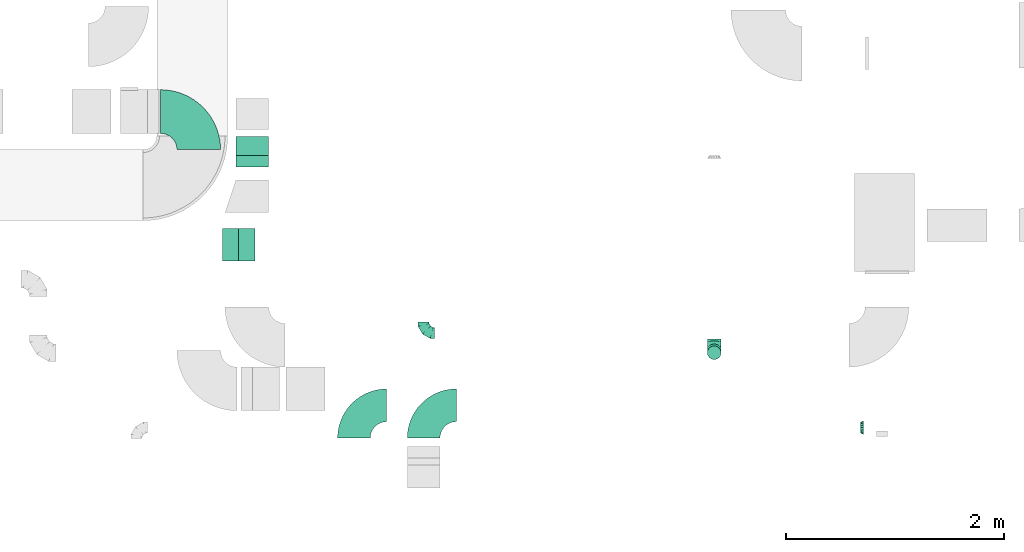
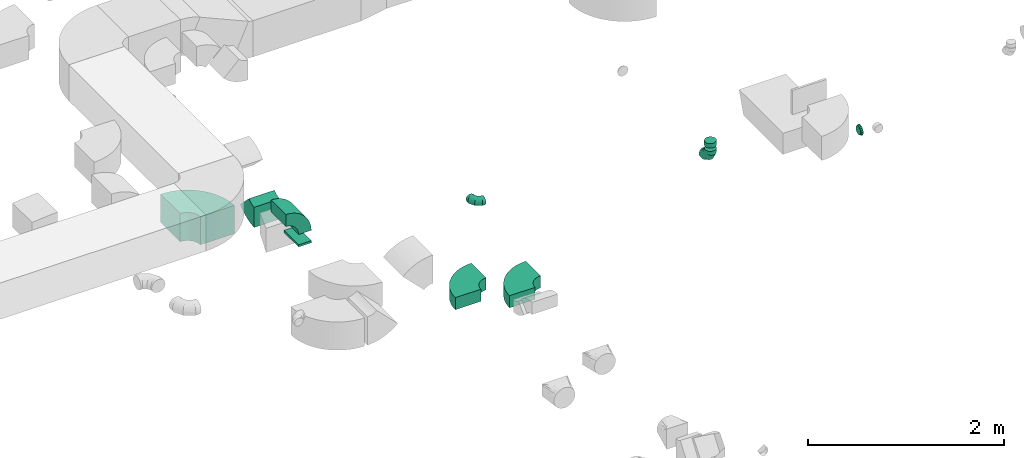
# One storey, part 11 of 44: 10 flow fittings.
"""IFC2X3 building model written with IfcOpenShell, lengths in millimetres."""

import ifcopenshell
import ifcopenshell.guid

model = None  # the IFC model being written
_history = None  # IfcOwnerHistory: only IFC2X3 demands one
_inside = {}  # id of a spatial element -> (the spatial element, [elements in it])
_under = {}  # id of a project, library or spatial element -> (it, [spatial elements below it])
_declared = {}  # id of a project -> (the project, [libraries it declares])
_typed = {}  # id of a type object -> (the type object, [elements of that type])
_made_of = {}  # id of a material, layer set ... -> (it, [elements and type objects made of it])


def new_model(schema):
    """Start an empty IFC model of exactly this schema.

    Asked for "IFC4X3", IfcOpenShell would pick the latest addendum, in which some entities
    have other attributes; the version numbers below select the first issue.
    IFC2X3 requires an IfcOwnerHistory on every rooted entity: one is made here for all.
    """
    global model, _history
    if schema == "IFC4X3":
        model = ifcopenshell.file(schema_version=(4, 3, 0, 0))
    else:
        model = ifcopenshell.file(schema=schema)
    _inside.clear()
    _under.clear()
    _declared.clear()
    _typed.clear()
    _made_of.clear()
    _history = None
    if model.schema == "IFC2X3":
        org = make("IfcOrganization", Name="unknown")
        user = make(
            "IfcPersonAndOrganization",
            ThePerson=make("IfcPerson", FamilyName="unknown"),
            TheOrganization=org,
        )
        app = make(
            "IfcApplication",
            ApplicationDeveloper=org,
            Version="unknown",
            ApplicationFullName="unknown",
            ApplicationIdentifier="unknown",
        )
        _history = make(
            "IfcOwnerHistory",
            OwningUser=user,
            OwningApplication=app,
            ChangeAction="ADDED",
            CreationDate=0,
        )
    return model


def make(cls, **values):
    """One entity of the class cls with the attributes given. An attribute that is None is left unset."""
    return model.create_entity(
        cls, **{name: value for name, value in values.items() if value is not None}
    )


def entity(cls, *values):
    """Any entity or typed value of the class cls, its attributes in the order of the schema. None: left unset."""
    e = model.create_entity(cls)
    for i, value in enumerate(values):
        if value is not None:
            e[i] = value
    return e


def rooted(cls, **values):
    """An entity with a GlobalId (a new one), such as an element, a storey or a relation."""
    return make(cls, GlobalId=ifcopenshell.guid.new(), OwnerHistory=_history, **values)


def si_unit(unit_type, name, prefix=None):
    """IfcSIUnit, for example si_unit("LENGTHUNIT", "METRE", prefix="MILLI")."""
    return make("IfcSIUnit", UnitType=unit_type, Prefix=prefix, Name=name)


def converted_unit(unit_type, name, factor, base, dimensions=None, offset=None):
    """IfcConversionBasedUnit, such as the inch: factor (a typed value) times the base unit."""
    return make(
        "IfcConversionBasedUnit"
        if offset is None
        else "IfcConversionBasedUnitWithOffset",
        ConversionOffset=offset,
        Dimensions=None
        if dimensions is None
        else entity("IfcDimensionalExponents", *dimensions),
        UnitType=unit_type,
        Name=name,
        ConversionFactor=make(
            "IfcMeasureWithUnit", ValueComponent=factor, UnitComponent=base
        ),
    )


def derived_unit(unit_type, elements):
    """IfcDerivedUnit: a product of units, each with its exponent."""
    return make(
        "IfcDerivedUnit",
        Elements=[
            make("IfcDerivedUnitElement", Unit=unit, Exponent=power)
            for unit, power in elements
        ],
        UnitType=unit_type,
    )


def assignment(units):
    """IfcUnitAssignment: the units of a project."""
    return None if units is None else make("IfcUnitAssignment", Units=units)


def point(xyz):
    """IfcCartesianPoint."""
    return None if xyz is None else make("IfcCartesianPoint", Coordinates=xyz)


def direction(xyz):
    """IfcDirection."""
    return None if xyz is None else make("IfcDirection", DirectionRatios=xyz)


def frame(location, z_axis=None, x_axis=None):
    """IfcAxis2Placement3D, a coordinate frame: its origin and axes. An axis left out is left unset."""
    return make(
        "IfcAxis2Placement3D",
        Location=point(location),
        Axis=direction(z_axis),
        RefDirection=direction(x_axis),
    )


def frame_2d(location, x_axis=None):
    """IfcAxis2Placement2D, a coordinate frame in the plane: its origin and x axis."""
    return make(
        "IfcAxis2Placement2D", Location=point(location), RefDirection=direction(x_axis)
    )


def origin():
    """The frame at (0, 0, 0) with its axes left unset."""
    return frame((0.0, 0.0, 0.0))


def origin_2d_with_axis():
    """The frame at (0, 0) in the plane with the x axis (1, 0) written out."""
    return frame_2d((0.0, 0.0), x_axis=(1.0, 0.0))


def place(relative_to, where):
    """IfcLocalPlacement: puts the frame where relative to a parent placement (None: the world)."""
    return make(
        "IfcLocalPlacement", PlacementRelTo=relative_to, RelativePlacement=where
    )


def context(
    kind, dimensions, precision=None, world=None, true_north=None, identifier=None
):
    """IfcGeometricRepresentationContext, for example the 3D "Model" context."""
    return make(
        "IfcGeometricRepresentationContext",
        ContextIdentifier=identifier,
        ContextType=kind,
        CoordinateSpaceDimension=dimensions,
        Precision=precision,
        WorldCoordinateSystem=world,
        TrueNorth=true_north,
    )


def subcontext(parent, identifier, kind, view, scale=None):
    """IfcGeometricRepresentationSubContext, for example "Body" below "Model"."""
    return make(
        "IfcGeometricRepresentationSubContext",
        ContextIdentifier=identifier,
        ContextType=kind,
        ParentContext=parent,
        TargetScale=scale,
        TargetView=view,
    )


def project(units=None, contexts=None):
    """IfcProject with its units and contexts."""
    return rooted(
        "IfcProject",
        Name="project",
        RepresentationContexts=contexts,
        UnitsInContext=assignment(units),
    )


def spatial(cls, under=None, at=None, **own):
    """A site, building, storey or space (cls), placed at a placement, below another one or the project."""
    s = rooted(cls, ObjectPlacement=at, **own)
    if under is not None:
        _under.setdefault(under.id(), (under, []))[1].append(s)
    return s


def polyline(points):
    """IfcPolyline through the points."""
    return make("IfcPolyline", Points=[point(p) for p in points])


def circle_curve(where, radius):
    """IfcCircle in the frame where."""
    return make("IfcCircle", Position=where, Radius=radius)


def parameter(value):
    """IfcParameterValue: where a trimmed curve begins or ends, as a parameter of its basis curve."""
    return model.create_entity("IfcParameterValue", value)


def trimmed(basis, trim1, trim2, sense, master):
    """IfcTrimmedCurve: the piece of a basis curve between two trims."""
    return make(
        "IfcTrimmedCurve",
        BasisCurve=basis,
        Trim1=trim1,
        Trim2=trim2,
        SenseAgreement=sense,
        MasterRepresentation=master,
    )


def segment(curve, same_sense, transition):
    """IfcCompositeCurveSegment."""
    return make(
        "IfcCompositeCurveSegment",
        Transition=transition,
        SameSense=same_sense,
        ParentCurve=curve,
    )


def composite_curve(segments, self_intersect=None):
    """IfcCompositeCurve: segments joined end to end."""
    return make("IfcCompositeCurve", Segments=segments, SelfIntersect=self_intersect)


def profile(cls, at=None, kind="AREA", **sizes):
    """A parametric profile (cls). Its sizes go by their IFC names, for example OverallWidth=200.0."""
    return make(cls, ProfileType=kind, Position=at, **sizes)


def rectangle(**sizes):
    """IfcRectangleProfileDef."""
    return profile("IfcRectangleProfileDef", **sizes)


def outline(outer, holes=None, kind="AREA"):
    """IfcArbitraryClosedProfileDef: a profile drawn as a closed curve; with holes, ...WithVoids."""
    if holes is None:
        return make("IfcArbitraryClosedProfileDef", ProfileType=kind, OuterCurve=outer)
    return make(
        "IfcArbitraryProfileDefWithVoids",
        ProfileType=kind,
        OuterCurve=outer,
        InnerCurves=holes,
    )


def extrude(swept, where, along, depth):
    """IfcExtrudedAreaSolid: the profile swept, set in the frame where, extruded along a direction by depth."""
    return make(
        "IfcExtrudedAreaSolid",
        SweptArea=swept,
        Position=where,
        ExtrudedDirection=direction(along),
        Depth=depth,
    )


def faces_of(points, faces, orient=None, outer=None):
    """IfcFace entities. A face is a list of loops; a loop is a list of indices into points, from 0.

    orient and outer hold one flag for each loop. By default every Orientation is true, the
    first loop of a face is its IfcFaceOuterBound and the others are IfcFaceBound.
    """
    made = []
    for i, loops in enumerate(faces):
        bounds = []
        for j, loop in enumerate(loops):
            is_outer = j == 0 if outer is None else outer[i][j]
            bounds.append(
                make(
                    "IfcFaceOuterBound" if is_outer else "IfcFaceBound",
                    Bound=make("IfcPolyLoop", Polygon=[points[k] for k in loop]),
                    Orientation=True if orient is None else orient[i][j],
                )
            )
        made.append(make("IfcFace", Bounds=bounds))
    return made


def faceted_brep(points, faces, orient=None, outer=None, voids=None):
    """IfcFacetedBrep: a solid bounded by flat faces; with voids (closed shells), ...WithVoids."""
    shared = [point(p) for p in points]
    hull = make("IfcClosedShell", CfsFaces=faces_of(shared, faces, orient, outer))
    if voids is None:
        return make("IfcFacetedBrep", Outer=hull)
    return make(
        "IfcFacetedBrepWithVoids",
        Outer=hull,
        Voids=[
            make(cls, CfsFaces=faces_of(shared, fs, o, b)) for cls, fs, o, b in voids
        ],
    )


def shape(context_of_items, identifier, shape_type, items):
    """IfcShapeRepresentation: the items that make up one representation, for example the "Body"."""
    return make(
        "IfcShapeRepresentation",
        ContextOfItems=context_of_items,
        RepresentationIdentifier=identifier,
        RepresentationType=shape_type,
        Items=items,
    )


def source(mapping_origin, context_of_items, identifier, shape_type, items):
    """IfcRepresentationMap: a shape defined once, which mapped items show again and again."""
    return make(
        "IfcRepresentationMap",
        MappingOrigin=mapping_origin,
        MappedRepresentation=shape(context_of_items, identifier, shape_type, items),
    )


def transform(
    local_origin,
    x_axis=None,
    y_axis=None,
    z_axis=None,
    scale=None,
    scale2=None,
    scale3=None,
    uniform=True,
):
    """IfcCartesianTransformationOperator3D, or its non-uniform kind. x_axis, y_axis, z_axis: its Axis1, 2, 3."""
    if uniform:
        return make(
            "IfcCartesianTransformationOperator3D",
            Axis1=direction(x_axis),
            Axis2=direction(y_axis),
            LocalOrigin=point(local_origin),
            Scale=scale,
            Axis3=direction(z_axis),
        )
    return make(
        "IfcCartesianTransformationOperator3DnonUniform",
        Axis1=direction(x_axis),
        Axis2=direction(y_axis),
        LocalOrigin=point(local_origin),
        Scale=scale,
        Axis3=direction(z_axis),
        Scale2=scale2,
        Scale3=scale3,
    )


def mapped(mapping_source, mapping_target):
    """IfcMappedItem: shows the shape of a source again, moved by a transform."""
    return make(
        "IfcMappedItem", MappingSource=mapping_source, MappingTarget=mapping_target
    )


def material(Name=None, Category=None):
    """IfcMaterial."""
    return make("IfcMaterial", Name=Name, Category=Category)


def made_of(thing, what):
    """Note that an element or type object is made of a material, layer set ...; save() writes the relation."""
    if what is not None:
        _made_of.setdefault(what.id(), (what, []))[1].append(thing)
    return thing


def type_object(cls, material=None, **own):
    """A type object (cls), such as IfcWallType, which elements share."""
    return made_of(rooted(cls, **own), material)


def type_shapes(of_type, sources):
    """Give a type object the sources (RepresentationMaps) that its elements show as mapped items."""
    of_type.RepresentationMaps = sources


def element(
    cls,
    number,
    at=None,
    inside=None,
    cuts=None,
    type_object=None,
    material=None,
    context=None,
    identifier="Body",
    shape_type=None,
    held_by="IfcProductDefinitionShape",
    body=None,
    shapes=None,
    **own,
):
    """One element of the class cls, such as IfcWall. Its Tag is "e" and its number.

    at: its placement. inside: the storey or other place that contains it. cuts: it is an
    opening in that element (IfcRelVoidsElement). A single representation is given by context,
    identifier, shape_type and body (its items); several are given by shapes. held_by: the class
    of the entity that holds the representations. save() writes the other relations.
    """
    e = rooted(cls, Tag="e%d" % number, ObjectPlacement=at, **own)
    if body is not None:
        shapes = [shape(context, identifier, shape_type, body)]
    if shapes is not None:
        e.Representation = make(held_by, Representations=shapes)
    if inside is not None:
        _inside.setdefault(inside.id(), (inside, []))[1].append(e)
    if cuts is not None:
        rooted(
            "IfcRelVoidsElement", RelatingBuildingElement=cuts, RelatedOpeningElement=e
        )
    if type_object is not None:
        _typed.setdefault(type_object.id(), (type_object, []))[1].append(e)
    return made_of(e, material)


def aggregate(whole, parts):
    """IfcRelAggregates: a whole, such as a stair, and the parts it consists of."""
    return rooted("IfcRelAggregates", RelatingObject=whole, RelatedObjects=parts)


def save(model, path):
    """Write the relations noted so far, then the file.

    IfcRelAggregates (storeys below a building ...), IfcRelContainedInSpatialStructure (elements
    in a storey), IfcRelDefinesByType, IfcRelAssociatesMaterial and IfcRelDeclares: one each for
    every whole, place, type object, material and project.
    """
    for whole, parts in _under.values():
        aggregate(whole, parts)
    for where, things in _inside.values():
        rooted(
            "IfcRelContainedInSpatialStructure",
            RelatedElements=things,
            RelatingStructure=where,
        )
    for kind, things in _typed.values():
        rooted("IfcRelDefinesByType", RelatedObjects=things, RelatingType=kind)
    for what, things in _made_of.values():
        rooted("IfcRelAssociatesMaterial", RelatedObjects=things, RelatingMaterial=what)
    for by, libraries in _declared.values():
        rooted("IfcRelDeclares", RelatingContext=by, RelatedDefinitions=libraries)
    model.write(path)


model = new_model("IFC2X3")

# Units and contexts
model_context = context("Model", 3, precision=0.01, world=origin(), true_north=direction((6.12303176911189e-17, 1.0)))
body_context = subcontext(model_context, "Body", "Model", "MODEL_VIEW")
ifc_project = project(units=[si_unit("LENGTHUNIT", "METRE", prefix="MILLI"), si_unit("AREAUNIT", "SQUARE_METRE"), si_unit("VOLUMEUNIT", "CUBIC_METRE"), converted_unit("PLANEANGLEUNIT", "DEGREE", entity("IfcRatioMeasure", 0.0174532925199433), si_unit("PLANEANGLEUNIT", "RADIAN"), dimensions=[0, 0, 0, 0, 0, 0, 0]), si_unit("MASSUNIT", "GRAM", prefix="KILO"), derived_unit("MASSDENSITYUNIT", [(si_unit("MASSUNIT", "GRAM", prefix="KILO"), 1), (si_unit("LENGTHUNIT", "METRE"), -3)]), derived_unit("MOMENTOFINERTIAUNIT", [(si_unit("LENGTHUNIT", "METRE"), 4)]), si_unit("TIMEUNIT", "SECOND"), si_unit("FREQUENCYUNIT", "HERTZ"), si_unit("THERMODYNAMICTEMPERATUREUNIT", "DEGREE_CELSIUS"), derived_unit("THERMALTRANSMITTANCEUNIT", [(si_unit("MASSUNIT", "GRAM", prefix="KILO"), 1), (si_unit("THERMODYNAMICTEMPERATUREUNIT", "KELVIN"), -1), (si_unit("TIMEUNIT", "SECOND"), -3)]), derived_unit("VOLUMETRICFLOWRATEUNIT", [(si_unit("LENGTHUNIT", "METRE"), 3), (si_unit("TIMEUNIT", "SECOND"), -1)]), derived_unit("MASSFLOWRATEUNIT", [(si_unit("MASSUNIT", "GRAM", prefix="KILO"), 1), (si_unit("TIMEUNIT", "SECOND"), -1)]), derived_unit("ROTATIONALFREQUENCYUNIT", [(si_unit("TIMEUNIT", "SECOND"), -1)]), si_unit("ELECTRICCURRENTUNIT", "AMPERE"), si_unit("ELECTRICVOLTAGEUNIT", "VOLT"), si_unit("POWERUNIT", "WATT"), si_unit("FORCEUNIT", "NEWTON", prefix="KILO"), si_unit("ILLUMINANCEUNIT", "LUX"), si_unit("LUMINOUSFLUXUNIT", "LUMEN"), si_unit("LUMINOUSINTENSITYUNIT", "CANDELA"), derived_unit("USERDEFINED", [(si_unit("MASSUNIT", "GRAM", prefix="KILO"), -1), (si_unit("LENGTHUNIT", "METRE"), -2), (si_unit("TIMEUNIT", "SECOND"), 3), (si_unit("LUMINOUSFLUXUNIT", "LUMEN"), 1)]), derived_unit("LINEARVELOCITYUNIT", [(si_unit("LENGTHUNIT", "METRE"), 1), (si_unit("TIMEUNIT", "SECOND"), -1)]), si_unit("PRESSUREUNIT", "PASCAL"), derived_unit("USERDEFINED", [(si_unit("LENGTHUNIT", "METRE"), -2), (si_unit("MASSUNIT", "GRAM", prefix="KILO"), 1), (si_unit("TIMEUNIT", "SECOND"), -2)]), derived_unit("LINEARFORCEUNIT", [(si_unit("MASSUNIT", "GRAM", prefix="KILO"), 1), (si_unit("LENGTHUNIT", "METRE"), 1), (si_unit("TIMEUNIT", "SECOND"), -2), (si_unit("LENGTHUNIT", "METRE"), -1)]), derived_unit("PLANARFORCEUNIT", [(si_unit("MASSUNIT", "GRAM", prefix="KILO"), 1), (si_unit("LENGTHUNIT", "METRE"), 1), (si_unit("TIMEUNIT", "SECOND"), -2), (si_unit("LENGTHUNIT", "METRE"), -2)])], contexts=[model_context])

# Site, building, storey
site_placement = place(None, origin())
site = spatial("IfcSite", under=ifc_project, at=site_placement, CompositionType="ELEMENT")
building_placement = place(site_placement, origin())
building = spatial("IfcBuilding", under=site, at=building_placement, CompositionType="ELEMENT")
storey_placement = place(building_placement, frame((0.0, 0.0, 15900.0)))
storey = spatial("IfcBuildingStorey", under=building, at=storey_placement, CompositionType="ELEMENT", Elevation=15900.0)

# Flow fittings
ifc_material = material()
duct_fitting_type_1 = type_object("IfcDuctFittingType", PredefinedType="NOTDEFINED", material=ifc_material)
shared_shape_1 = source(origin(), body_context, "Body", "SweptSolid", [
    extrude(rectangle(XDim=26.0960000000005, YDim=300.0, at=origin_2d_with_axis()), frame((6.95, 0.0, -75.0)), (0.0, 0.0, 1.0), 150.0),
])
type_shapes(duct_fitting_type_1, [shared_shape_1])
flow_fitting_1_placement = place(storey_placement, frame((18500.31, 11046.76, 3000.0), z_axis=(1.0, 0.0, 0.0), x_axis=(0.0, 0.0, 1.0)))
element("IfcFlowFitting", 1, at=flow_fitting_1_placement, inside=storey, type_object=duct_fitting_type_1, material=ifc_material, context=body_context, shape_type="MappedRepresentation", body=[
    mapped(shared_shape_1, transform((0.0, 0.0, 0.0), scale=1.0)),
])
duct_fitting_type_2 = type_object("IfcDuctFittingType", PredefinedType="NOTDEFINED", material=ifc_material)
shared_shape_2 = source(origin(), body_context, "Body", "Brep", [
    faceted_brep([(-100.0, 0.0, -50.0), (-100.0, -12.94, -48.3), (-100.0, -25.0, -43.3), (-100.0, -35.36, -35.36), (-100.0, -43.3, -25.0), (-100.0, -48.3, -12.94), (-100.0, -50.0, 0.0), (-100.0, -48.3, 12.94), (-100.0, -43.3, 25.0), (-100.0, -35.36, 35.36), (-100.0, -25.0, 43.3), (-100.0, -12.94, 48.3), (-100.0, 0.0, 50.0), (-100.0, 12.94, 48.3), (-100.0, 25.0, 43.3), (-100.0, 35.36, 35.36), (-100.0, 43.3, 25.0), (-100.0, 48.3, 12.94), (-100.0, 50.0, 0.0), (-100.0, 48.3, -12.94), (-100.0, 43.3, -25.0), (-100.0, 35.36, -35.36), (-100.0, 25.0, -43.3), (-100.0, 12.94, -48.3), (-76.67, 12.94, 48.3), (-79.9, 25.0, 43.3), (-73.21, 0.0, 50.0), (-82.68, 35.36, 35.36), (-86.15, 48.3, 12.94), (-86.6, 50.0, 0.0), (-84.81, 43.3, 25.0), (-84.81, 43.3, -25.0), (-82.68, 35.36, -35.36), (-86.15, 48.3, -12.94), (-76.67, 12.94, -48.3), (-73.21, 0.0, -50.0), (-79.9, 25.0, -43.3), (-69.74, -12.94, -48.3), (-66.51, -25.0, -43.3), (-63.73, -35.36, -35.36), (-61.6, -43.3, -25.0), (-60.26, -48.3, -12.94), (-59.81, -50.0, 0.0), (-60.26, -48.3, 12.94), (-61.6, -43.3, 25.0), (-63.73, -35.36, 35.36), (-66.51, -25.0, 43.3), (-69.74, -12.94, 48.3), (-36.27, 36.27, 48.3), (-45.1, 45.1, 43.3), (-26.79, 26.79, 50.0), (-52.68, 52.68, 35.36), (-58.49, 58.49, 25.0), (-62.15, 62.15, 12.94), (-63.4, 63.4, 0.0), (-62.15, 62.15, -12.94), (-58.49, 58.49, -25.0), (-52.68, 52.68, -35.36), (-36.27, 36.27, -48.3), (-26.79, 26.79, -50.0), (-45.1, 45.1, -43.3), (-17.32, 17.32, -48.3), (-8.49, 8.49, -43.3), (-0.91, 0.91, -35.36), (4.9, -4.9, -25.0), (8.56, -8.56, -12.94), (9.81, -9.81, 0.0), (8.56, -8.56, 12.94), (4.9, -4.9, 25.0), (-0.91, 0.91, 35.36), (-8.49, 8.49, 43.3), (-17.32, 17.32, 48.3), (-12.94, 76.67, 48.3), (-25.0, 79.9, 43.3), (0.0, 73.21, 50.0), (-35.36, 82.68, 35.36), (-43.3, 84.81, 25.0), (-48.3, 86.15, 12.94), (-50.0, 86.6, 0.0), (-48.3, 86.15, -12.94), (-43.3, 84.81, -25.0), (-35.36, 82.68, -35.36), (-12.94, 76.67, -48.3), (0.0, 73.21, -50.0), (-25.0, 79.9, -43.3), (12.94, 69.74, -48.3), (25.0, 66.51, -43.3), (35.36, 63.73, -35.36), (43.3, 61.6, -25.0), (48.3, 60.26, -12.94), (50.0, 59.81, 0.0), (48.3, 60.26, 12.94), (43.3, 61.6, 25.0), (35.36, 63.73, 35.36), (25.0, 66.51, 43.3), (12.94, 69.74, 48.3), (-12.94, 100.0, -48.3), (-25.0, 100.0, -43.3), (-35.36, 100.0, -35.36), (-43.3, 100.0, -25.0), (-48.3, 100.0, -12.94), (-50.0, 100.0, 0.0), (-48.3, 100.0, 12.94), (-43.3, 100.0, 25.0), (-35.36, 100.0, 35.36), (-25.0, 100.0, 43.3), (-12.94, 100.0, 48.3), (0.0, 100.0, 50.0), (12.94, 100.0, 48.3), (25.0, 100.0, 43.3), (35.36, 100.0, 35.36), (43.3, 100.0, 25.0), (48.3, 100.0, 12.94), (50.0, 100.0, 0.0), (48.3, 100.0, -12.94), (43.3, 100.0, -25.0), (35.36, 100.0, -35.36), (25.0, 100.0, -43.3), (12.94, 100.0, -48.3), (0.0, 100.0, -50.0)], [[[0, 1, 2, 3, 4, 5, 6, 7, 8, 9, 10, 11, 12, 13, 14, 15, 16, 17, 18, 19, 20, 21, 22, 23]], [[24, 25, 14, 13]], [[26, 24, 13, 12]], [[14, 25, 27, 15]], [[28, 29, 18, 17]], [[30, 28, 17, 16]], [[15, 27, 30, 16]], [[20, 31, 32, 21]], [[33, 31, 20, 19]], [[18, 29, 33, 19]], [[34, 35, 0, 23]], [[36, 34, 23, 22]], [[32, 36, 22, 21]], [[2, 1, 37, 38]], [[3, 2, 38, 39]], [[0, 35, 37, 1]], [[5, 4, 40, 41]], [[6, 5, 41, 42]], [[3, 39, 40, 4]], [[6, 42, 43, 7]], [[7, 43, 44, 8]], [[8, 44, 45, 9]], [[10, 46, 47, 11]], [[11, 47, 26, 12]], [[10, 9, 45, 46]], [[48, 49, 25, 24]], [[50, 48, 24, 26]], [[27, 25, 49, 51]], [[52, 53, 28, 30]], [[51, 52, 30, 27]], [[29, 28, 53, 54]], [[55, 56, 31, 33]], [[54, 55, 33, 29]], [[57, 32, 31, 56]], [[58, 59, 35, 34]], [[60, 58, 34, 36]], [[57, 60, 36, 32]], [[37, 35, 59, 61]], [[38, 37, 61, 62]], [[39, 38, 62, 63]], [[41, 40, 64, 65]], [[42, 41, 65, 66]], [[63, 64, 40, 39]], [[43, 42, 66, 67]], [[44, 43, 67, 68]], [[68, 69, 45, 44]], [[46, 45, 69, 70]], [[47, 46, 70, 71]], [[26, 47, 71, 50]], [[72, 73, 49, 48]], [[74, 72, 48, 50]], [[51, 49, 73, 75]], [[76, 77, 53, 52]], [[75, 76, 52, 51]], [[54, 53, 77, 78]], [[79, 80, 56, 55]], [[78, 79, 55, 54]], [[81, 57, 56, 80]], [[82, 83, 59, 58]], [[84, 82, 58, 60]], [[81, 84, 60, 57]], [[61, 59, 83, 85]], [[62, 61, 85, 86]], [[63, 62, 86, 87]], [[65, 64, 88, 89]], [[66, 65, 89, 90]], [[87, 88, 64, 63]], [[67, 66, 90, 91]], [[68, 67, 91, 92]], [[92, 93, 69, 68]], [[70, 69, 93, 94]], [[71, 70, 94, 95]], [[50, 71, 95, 74]], [[96, 97, 98, 99, 100, 101, 102, 103, 104, 105, 106, 107, 108, 109, 110, 111, 112, 113, 114, 115, 116, 117, 118, 119]], [[72, 74, 107, 106]], [[73, 72, 106, 105]], [[75, 73, 105, 104]], [[77, 76, 103, 102]], [[78, 77, 102, 101]], [[75, 104, 103, 76]], [[78, 101, 100, 79]], [[79, 100, 99, 80]], [[80, 99, 98, 81]], [[96, 119, 83, 82]], [[97, 96, 82, 84]], [[84, 81, 98, 97]], [[83, 119, 118, 85]], [[85, 118, 117, 86]], [[86, 117, 116, 87]], [[88, 115, 114, 89]], [[89, 114, 113, 90]], [[87, 116, 115, 88]], [[91, 90, 113, 112]], [[92, 91, 112, 111]], [[93, 92, 111, 110]], [[95, 94, 109, 108]], [[74, 95, 108, 107]], [[110, 109, 94, 93]]]),
])
type_shapes(duct_fitting_type_2, [shared_shape_2])
flow_fitting_2_placement = place(storey_placement, frame((20119.89, 10237.4, 3350.0), z_axis=(0.0, -1.44399280795024e-06, 1.0), x_axis=(0.0, -1.0, -1.44399280795024e-06)))
element("IfcFlowFitting", 2, at=flow_fitting_2_placement, inside=storey, type_object=duct_fitting_type_2, material=ifc_material, context=body_context, shape_type="MappedRepresentation", body=[
    mapped(shared_shape_2, transform((0.0, 0.0, 0.0), scale=1.0)),
])
duct_fitting_type_3 = type_object("IfcDuctFittingType", PredefinedType="NOTDEFINED", material=ifc_material)
shared_shape_3 = source(origin(), body_context, "Body", "Brep", [
    faceted_brep([(-125.0, 0.0, -62.5), (-125.0, -16.18, -60.37), (-125.0, -31.25, -54.13), (-125.0, -44.19, -44.19), (-125.0, -54.13, -31.25), (-125.0, -60.37, -16.18), (-125.0, -62.5, 0.0), (-125.0, -60.37, 16.18), (-125.0, -54.13, 31.25), (-125.0, -44.19, 44.19), (-125.0, -31.25, 54.13), (-125.0, -16.18, 60.37), (-125.0, 0.0, 62.5), (-125.0, 16.18, 60.37), (-125.0, 31.25, 54.13), (-125.0, 44.19, 44.19), (-125.0, 54.13, 31.25), (-125.0, 60.37, 16.18), (-125.0, 62.5, 0.0), (-125.0, 60.37, -16.18), (-125.0, 54.13, -31.25), (-125.0, 44.19, -44.19), (-125.0, 31.25, -54.13), (-125.0, 16.18, -60.37), (-95.84, 16.18, 60.37), (-99.88, 31.25, 54.13), (-91.51, 0.0, 62.5), (-103.35, 44.19, 44.19), (-107.68, 60.37, 16.18), (-108.25, 62.5, 0.0), (-106.01, 54.13, 31.25), (-106.01, 54.13, -31.25), (-103.35, 44.19, -44.19), (-107.68, 60.37, -16.18), (-95.84, 16.18, -60.37), (-91.51, 0.0, -62.5), (-99.88, 31.25, -54.13), (-87.17, -16.18, -60.37), (-83.13, -31.25, -54.13), (-79.66, -44.19, -44.19), (-77.0, -54.13, -31.25), (-75.33, -60.37, -16.18), (-74.76, -62.5, 0.0), (-75.33, -60.37, 16.18), (-77.0, -54.13, 31.25), (-79.66, -44.19, 44.19), (-83.13, -31.25, 54.13), (-87.17, -16.18, 60.37), (-45.34, 45.34, 60.37), (-56.37, 56.37, 54.13), (-33.49, 33.49, 62.5), (-65.85, 65.85, 44.19), (-73.12, 73.12, 31.25), (-77.69, 77.69, 16.18), (-79.25, 79.25, 0.0), (-77.69, 77.69, -16.18), (-73.12, 73.12, -31.25), (-65.85, 65.85, -44.19), (-45.34, 45.34, -60.37), (-33.49, 33.49, -62.5), (-56.37, 56.37, -54.13), (-21.65, 21.65, -60.37), (-10.62, 10.62, -54.13), (-1.14, 1.14, -44.19), (6.13, -6.13, -31.25), (10.7, -10.7, -16.18), (12.26, -12.26, 0.0), (10.7, -10.7, 16.18), (6.13, -6.13, 31.25), (-1.14, 1.14, 44.19), (-10.62, 10.62, 54.13), (-21.65, 21.65, 60.37), (-16.18, 95.84, 60.37), (-31.25, 99.88, 54.13), (0.0, 91.51, 62.5), (-44.19, 103.35, 44.19), (-54.13, 106.01, 31.25), (-60.37, 107.68, 16.18), (-62.5, 108.25, 0.0), (-60.37, 107.68, -16.18), (-54.13, 106.01, -31.25), (-44.19, 103.35, -44.19), (-16.18, 95.84, -60.37), (0.0, 91.51, -62.5), (-31.25, 99.88, -54.13), (16.18, 87.17, -60.37), (31.25, 83.13, -54.13), (44.19, 79.66, -44.19), (54.13, 77.0, -31.25), (60.37, 75.33, -16.18), (62.5, 74.76, 0.0), (60.37, 75.33, 16.18), (54.13, 77.0, 31.25), (44.19, 79.66, 44.19), (31.25, 83.13, 54.13), (16.18, 87.17, 60.37), (-16.18, 125.0, -60.37), (-31.25, 125.0, -54.13), (-44.19, 125.0, -44.19), (-54.13, 125.0, -31.25), (-60.37, 125.0, -16.18), (-62.5, 125.0, 0.0), (-60.37, 125.0, 16.18), (-54.13, 125.0, 31.25), (-44.19, 125.0, 44.19), (-31.25, 125.0, 54.13), (-16.18, 125.0, 60.37), (0.0, 125.0, 62.5), (16.18, 125.0, 60.37), (31.25, 125.0, 54.13), (44.19, 125.0, 44.19), (54.13, 125.0, 31.25), (60.37, 125.0, 16.18), (62.5, 125.0, 0.0), (60.37, 125.0, -16.18), (54.13, 125.0, -31.25), (44.19, 125.0, -44.19), (31.25, 125.0, -54.13), (16.18, 125.0, -60.37), (0.0, 125.0, -62.5)], [[[0, 1, 2, 3, 4, 5, 6, 7, 8, 9, 10, 11, 12, 13, 14, 15, 16, 17, 18, 19, 20, 21, 22, 23]], [[24, 25, 14, 13]], [[26, 24, 13, 12]], [[14, 25, 27, 15]], [[28, 29, 18, 17]], [[30, 28, 17, 16]], [[15, 27, 30, 16]], [[20, 31, 32, 21]], [[33, 31, 20, 19]], [[18, 29, 33, 19]], [[34, 35, 0, 23]], [[36, 34, 23, 22]], [[21, 32, 36, 22]], [[1, 0, 35, 37]], [[2, 1, 37, 38]], [[38, 39, 3, 2]], [[5, 4, 40, 41]], [[6, 5, 41, 42]], [[39, 40, 4, 3]], [[6, 42, 43, 7]], [[7, 43, 44, 8]], [[45, 9, 8, 44]], [[9, 45, 46, 10]], [[10, 46, 47, 11]], [[26, 12, 11, 47]], [[48, 49, 25, 24]], [[50, 48, 24, 26]], [[27, 25, 49, 51]], [[52, 53, 28, 30]], [[51, 52, 30, 27]], [[29, 28, 53, 54]], [[55, 56, 31, 33]], [[54, 55, 33, 29]], [[57, 32, 31, 56]], [[58, 59, 35, 34]], [[60, 58, 34, 36]], [[57, 60, 36, 32]], [[37, 35, 59, 61]], [[38, 37, 61, 62]], [[39, 38, 62, 63]], [[41, 40, 64, 65]], [[42, 41, 65, 66]], [[63, 64, 40, 39]], [[43, 42, 66, 67]], [[44, 43, 67, 68]], [[68, 69, 45, 44]], [[46, 45, 69, 70]], [[47, 46, 70, 71]], [[26, 47, 71, 50]], [[72, 73, 49, 48]], [[74, 72, 48, 50]], [[51, 49, 73, 75]], [[76, 77, 53, 52]], [[75, 76, 52, 51]], [[54, 53, 77, 78]], [[79, 80, 56, 55]], [[78, 79, 55, 54]], [[81, 57, 56, 80]], [[82, 83, 59, 58]], [[84, 82, 58, 60]], [[81, 84, 60, 57]], [[61, 59, 83, 85]], [[62, 61, 85, 86]], [[63, 62, 86, 87]], [[65, 64, 88, 89]], [[66, 65, 89, 90]], [[87, 88, 64, 63]], [[67, 66, 90, 91]], [[68, 67, 91, 92]], [[92, 93, 69, 68]], [[70, 69, 93, 94]], [[71, 70, 94, 95]], [[50, 71, 95, 74]], [[96, 97, 98, 99, 100, 101, 102, 103, 104, 105, 106, 107, 108, 109, 110, 111, 112, 113, 114, 115, 116, 117, 118, 119]], [[72, 74, 107, 106]], [[73, 72, 106, 105]], [[75, 73, 105, 104]], [[77, 76, 103, 102]], [[78, 77, 102, 101]], [[75, 104, 103, 76]], [[78, 101, 100, 79]], [[79, 100, 99, 80]], [[80, 99, 98, 81]], [[96, 119, 83, 82]], [[97, 96, 82, 84]], [[84, 81, 98, 97]], [[83, 119, 118, 85]], [[85, 118, 117, 86]], [[116, 87, 86, 117]], [[88, 115, 114, 89]], [[89, 114, 113, 90]], [[115, 88, 87, 116]], [[91, 90, 113, 112]], [[92, 91, 112, 111]], [[111, 110, 93, 92]], [[95, 94, 109, 108]], [[74, 95, 108, 107]], [[110, 109, 94, 93]]]),
])
type_shapes(duct_fitting_type_3, [shared_shape_3])
flow_fitting_3_placement = place(storey_placement, frame((22782.58, 10057.12, 3085.0), z_axis=(-1.0, 0.0, 0.0), x_axis=(0.0, -1.0, 0.0)))
element("IfcFlowFitting", 3, at=flow_fitting_3_placement, inside=storey, type_object=duct_fitting_type_3, material=ifc_material, context=body_context, shape_type="MappedRepresentation", body=[
    mapped(shared_shape_3, transform((0.0, 0.0, 0.0), scale=1.0)),
])
duct_fitting_type_4 = type_object("IfcDuctFittingType", PredefinedType="NOTDEFINED", material=ifc_material)
shared_shape_4 = source(origin(), body_context, "Body", "Brep", [
    faceted_brep([(25.0, -46.19, 19.13), (25.0, -48.1, 9.57), (25.0, -50.0, 0.0), (25.0, -48.1, -9.57), (25.0, -46.19, -19.13), (25.0, -40.77, -27.24), (25.0, -35.36, -35.36), (25.0, -27.24, -40.77), (25.0, -19.13, -46.19), (25.0, -9.57, -48.1), (25.0, 0.0, -50.0), (25.0, 9.57, -48.1), (25.0, 19.13, -46.19), (25.0, 27.24, -40.77), (25.0, 35.36, -35.36), (25.0, 40.77, -27.24), (25.0, 46.19, -19.13), (25.0, 48.1, -9.57), (25.0, 50.0, 0.0), (25.0, 48.1, 9.57), (25.0, 46.19, 19.13), (25.0, 40.77, 27.24), (25.0, 35.36, 35.36), (25.0, 27.24, 40.77), (25.0, 19.13, 46.19), (25.0, 9.57, 48.1), (25.0, 0.0, 50.0), (25.0, -9.57, 48.1), (25.0, -19.13, 46.19), (25.0, -27.24, 40.77), (25.0, -35.36, 35.36), (25.0, -40.77, 27.24), (0.0, -62.5, 0.0), (0.0, -60.02, 12.45), (0.0, -57.74, 23.92), (0.0, -50.97, 34.06), (0.0, -44.19, 44.19), (0.0, -34.06, 50.97), (0.0, -23.92, 57.74), (0.0, -12.45, 60.02), (0.0, 0.0, 62.5), (0.0, 12.45, 60.02), (0.0, 23.92, 57.74), (0.0, 34.06, 50.97), (0.0, 44.19, 44.19), (0.0, 50.97, 34.06), (0.0, 57.74, 23.92), (0.0, 60.02, 12.45), (0.0, 62.5, 0.0), (0.0, 60.02, -12.45), (0.0, 57.74, -23.92), (0.0, 50.97, -34.06), (0.0, 44.19, -44.19), (0.0, 34.06, -50.97), (0.0, 23.92, -57.74), (0.0, 12.45, -60.02), (0.0, 0.0, -62.5), (0.0, -12.45, -60.02), (0.0, -23.92, -57.74), (0.0, -34.06, -50.97), (0.0, -44.19, -44.19), (0.0, -50.97, -34.06), (0.0, -57.74, -23.92), (0.0, -60.02, -12.45)], [[[0, 1, 2, 3, 4, 5, 6, 7, 8, 9, 10, 11, 12, 13, 14, 15, 16, 17, 18, 19, 20, 21, 22, 23, 24, 25, 26, 27, 28, 29, 30, 31]], [[32, 33, 34, 35, 36, 37, 38, 39, 40, 41, 42, 43, 44, 45, 46, 47, 48, 49, 50, 51, 52, 53, 54, 55, 56, 57, 58, 59, 60, 61, 62, 63]], [[24, 42, 41, 40, 26, 25]], [[22, 44, 43, 42, 24, 23]], [[48, 47, 46, 20, 19, 18]], [[44, 22, 21, 20, 46, 45]], [[0, 34, 33, 32, 2, 1]], [[30, 36, 35, 34, 0, 31]], [[40, 39, 38, 28, 27, 26]], [[36, 30, 29, 28, 38, 37]], [[8, 58, 57, 56, 10, 9]], [[6, 60, 59, 58, 8, 7]], [[32, 63, 62, 4, 3, 2]], [[60, 6, 5, 4, 62, 61]], [[16, 50, 49, 48, 18, 17]], [[14, 52, 51, 50, 16, 15]], [[56, 55, 54, 12, 11, 10]], [[52, 14, 13, 12, 54, 53]]]),
])
type_shapes(duct_fitting_type_4, [shared_shape_4])
flow_fitting_4_placement = place(storey_placement, frame((24149.84, 9370.12, 3375.0), z_axis=(0.0, 0.0, 1.0), x_axis=(-1.0, 0.0, 0.0)))
element("IfcFlowFitting", 4, at=flow_fitting_4_placement, inside=storey, type_object=duct_fitting_type_4, material=ifc_material, context=body_context, shape_type="MappedRepresentation", body=[
    mapped(shared_shape_4, transform((0.0, 0.0, 0.0), scale=1.0)),
])
duct_fitting_type_5 = type_object("IfcDuctFittingType", PredefinedType="NOTDEFINED", material=ifc_material)
shared_shape_5 = source(origin(), body_context, "Body", "Brep", [
    faceted_brep([(20.0, 0.0, -62.5), (20.0, 16.18, -60.37), (20.0, 31.25, -54.13), (20.0, 44.19, -44.19), (20.0, 54.13, -31.25), (20.0, 60.37, -16.18), (20.0, 62.5, 0.0), (20.0, 60.37, 16.18), (20.0, 54.13, 31.25), (20.0, 44.19, 44.19), (20.0, 31.25, 54.13), (20.0, 16.18, 60.37), (20.0, 0.0, 62.5), (20.0, -16.18, 60.37), (20.0, -31.25, 54.13), (20.0, -44.19, 44.19), (20.0, -54.13, 31.25), (20.0, -60.37, 16.18), (20.0, -62.5, 0.0), (20.0, -60.37, -16.18), (20.0, -54.13, -31.25), (20.0, -44.19, -44.19), (20.0, -31.25, -54.13), (20.0, -16.18, -60.37), (0.0, 0.0, 62.5), (-36.16, 0.0, 62.5), (-36.16, -16.18, 60.37), (0.0, -16.18, 60.37), (-36.16, -31.25, 54.13), (0.0, -31.25, 54.13), (0.0, -44.19, 44.19), (-36.16, -44.19, 44.19), (0.0, -54.13, 31.25), (-36.16, -54.13, 31.25), (-36.16, -60.37, 16.18), (0.0, -60.37, 16.18), (-36.16, -62.5, 0.0), (0.0, -62.5, 0.0), (-36.16, -60.37, -16.18), (0.0, -60.37, -16.18), (-36.16, -54.13, -31.25), (0.0, -54.13, -31.25), (0.0, -44.19, -44.19), (-36.16, -44.19, -44.19), (0.0, -31.25, -54.13), (-36.16, -31.25, -54.13), (-36.16, -16.18, -60.37), (0.0, -16.18, -60.37), (-36.16, 0.0, -62.5), (0.0, 0.0, -62.5), (-36.16, 16.18, -60.37), (0.0, 16.18, -60.37), (-36.16, 31.25, -54.13), (0.0, 31.25, -54.13), (0.0, 44.19, -44.19), (-36.16, 44.19, -44.19), (0.0, 54.13, -31.25), (-36.16, 54.13, -31.25), (-36.16, 60.37, -16.18), (0.0, 60.37, -16.18), (-36.16, 62.5, 0.0), (0.0, 62.5, 0.0), (-36.16, 60.37, 16.18), (0.0, 60.37, 16.18), (-36.16, 54.13, 31.25), (0.0, 54.13, 31.25), (0.0, 44.19, 44.19), (-36.16, 44.19, 44.19), (0.0, 31.25, 54.13), (-36.16, 31.25, 54.13), (-36.16, 16.18, 60.37), (0.0, 16.18, 60.37)], [[[0, 1, 2, 3, 4, 5, 6, 7, 8, 9, 10, 11, 12, 13, 14, 15, 16, 17, 18, 19, 20, 21, 22, 23]], [[13, 12, 24, 25, 26, 27]], [[14, 13, 27, 26, 28, 29]], [[30, 15, 14, 29, 28, 31]], [[17, 16, 32, 33, 34, 35]], [[18, 17, 35, 34, 36, 37]], [[32, 16, 15, 30, 31, 33]], [[19, 18, 37, 36, 38, 39]], [[20, 19, 39, 38, 40, 41]], [[42, 21, 20, 41, 40, 43]], [[23, 22, 44, 45, 46, 47]], [[0, 23, 47, 46, 48, 49]], [[44, 22, 21, 42, 43, 45]], [[1, 0, 49, 48, 50, 51]], [[2, 1, 51, 50, 52, 53]], [[54, 3, 2, 53, 52, 55]], [[5, 4, 56, 57, 58, 59]], [[6, 5, 59, 58, 60, 61]], [[56, 4, 3, 54, 55, 57]], [[7, 6, 61, 60, 62, 63]], [[8, 7, 63, 62, 64, 65]], [[66, 9, 8, 65, 64, 67]], [[11, 10, 68, 69, 70, 71]], [[12, 11, 71, 70, 25, 24]], [[68, 10, 9, 66, 67, 69]], [[46, 45, 43, 40, 38, 36, 34, 33, 31, 28, 26, 25, 70, 69, 67, 64, 62, 60, 58, 57, 55, 52, 50, 48]]]),
])
type_shapes(duct_fitting_type_5, [shared_shape_5])
flow_fitting_5_placement = place(storey_placement, frame((22782.58, 10057.12, 3270.0), z_axis=(0.0, 1.0, 0.0), x_axis=(0.0, 0.0, -1.0)))
element("IfcFlowFitting", 5, at=flow_fitting_5_placement, inside=storey, type_object=duct_fitting_type_5, material=ifc_material, context=body_context, shape_type="MappedRepresentation", body=[
    mapped(shared_shape_5, transform((0.0, 0.0, 0.0), scale=1.0)),
])
duct_fitting_type_6 = type_object("IfcDuctFittingType", PredefinedType="NOTDEFINED", material=ifc_material)
shared_shape_6 = source(origin(), body_context, "Body", "SweptSolid", [
    extrude(outline(composite_curve([segment(polyline([(-300.0, -150.0), (0.0, -150.0)]), True, "CONTINUOUS"), segment(trimmed(circle_curve(frame_2d((150.0, -150.0), x_axis=(0.0, 1.0)), 150.0), [parameter(0.0)], [parameter(90.0)], True, "PARAMETER"), False, "CONTINUOUS"), segment(polyline([(150.0, 0.0), (150.0, 300.0)]), True, "CONTINUOUS"), segment(trimmed(circle_curve(frame_2d((150.0, -150.0), x_axis=(0.0, 1.0)), 450.0), [parameter(0.0)], [parameter(90.0000000000001)], True, "PARAMETER"), True, "CONTINUOUS")], self_intersect=False)), frame((-150.0, 150.0, -75.0), z_axis=(0.0, 0.0, 1.0), x_axis=(-1.0, 0.0, 0.0)), (0.0, 0.0, 1.0), 150.0),
])
type_shapes(duct_fitting_type_6, [shared_shape_6])
for number, where, z_axis, x_axis in (
    (6, (20120.04, 9575.61, 2755.0), (0.0, 0.0, 1.0), (-1.0, 0.0, 0.0)),
    (7, (19481.36, 9575.09, 2955.0), (0.0, 0.0, 1.0), (-1.0, 0.0, 0.0)),
):
    element("IfcFlowFitting", number, at=place(storey_placement, frame(where, z_axis=z_axis, x_axis=x_axis)), inside=storey, type_object=duct_fitting_type_6, material=ifc_material, context=body_context, shape_type="MappedRepresentation", body=[
        mapped(shared_shape_6, transform((0.0, 0.0, 0.0), scale=1.0)),
    ])
duct_fitting_type_7 = type_object("IfcDuctFittingType", PredefinedType="NOTDEFINED", material=ifc_material)
shared_shape_7 = source(origin(), body_context, "Body", "SweptSolid", [
    extrude(outline(composite_curve([segment(polyline([(-187.5, -112.5), (-37.5, -112.5)]), True, "CONTINUOUS"), segment(trimmed(circle_curve(frame_2d((112.5, -112.5), x_axis=(0.0, 1.0)), 150.0), [parameter(0.0)], [parameter(90.0000000000001)], True, "PARAMETER"), False, "CONTINUOUS"), segment(polyline([(112.5, 37.5), (112.5, 187.5)]), True, "CONTINUOUS"), segment(trimmed(circle_curve(frame_2d((112.5, -112.5), x_axis=(0.0, 1.0)), 300.0), [parameter(0.0)], [parameter(90.0000000000001)], True, "PARAMETER"), True, "CONTINUOUS")], self_intersect=False)), frame((-112.5, 112.5, -150.0), z_axis=(0.0, 0.0, 1.0), x_axis=(-1.0, 0.0, 0.0)), (0.0, 0.0, 1.0), 300.0),
])
type_shapes(duct_fitting_type_7, [shared_shape_7])
flow_fitting_6_placement = place(storey_placement, frame((18500.31, 11046.76, 3375.0), z_axis=(0.0, 1.0, 0.0), x_axis=(1.0, 0.0, 0.0)))
element("IfcFlowFitting", 8, at=flow_fitting_6_placement, inside=storey, type_object=duct_fitting_type_7, material=ifc_material, context=body_context, shape_type="MappedRepresentation", body=[
    mapped(shared_shape_7, transform((0.0, 0.0, 0.0), scale=1.0)),
])
duct_fitting_type_8 = type_object("IfcDuctFittingType", PredefinedType="NOTDEFINED", material=ifc_material)
shared_shape_8 = source(origin(), body_context, "Body", "SweptSolid", [
    extrude(outline(composite_curve([segment(polyline([(-375.0, -175.0), (25.0, -175.0)]), True, "CONTINUOUS"), segment(trimmed(circle_curve(frame_2d((175.0, -175.0), x_axis=(0.0, 1.0)), 150.0), [parameter(0.0)], [parameter(90.0000000000001)], True, "PARAMETER"), False, "CONTINUOUS"), segment(polyline([(175.0, -25.0), (175.0, 375.0)]), True, "CONTINUOUS"), segment(trimmed(circle_curve(frame_2d((175.0, -175.0), x_axis=(0.0, 1.0)), 550.0), [parameter(0.0)], [parameter(90.0)], True, "PARAMETER"), True, "CONTINUOUS")], self_intersect=False)), frame((-175.0, 175.0, -175.0), z_axis=(0.0, 0.0, 1.0), x_axis=(-1.0, 0.0, 0.0)), (0.0, 0.0, 1.0), 350.0),
])
type_shapes(duct_fitting_type_8, [shared_shape_8])
flow_fitting_7_placement = place(storey_placement, frame((18059.23, 12267.41, 2775.0), z_axis=(0.0, 0.0, 1.0), x_axis=(0.0, 1.0, 0.0)))
element("IfcFlowFitting", 9, at=flow_fitting_7_placement, inside=storey, type_object=duct_fitting_type_8, material=ifc_material, context=body_context, shape_type="MappedRepresentation", body=[
    mapped(shared_shape_8, transform((0.0, 0.0, 0.0), scale=1.0)),
])
duct_fitting_type_9 = type_object("IfcDuctFittingType", PredefinedType="NOTDEFINED", material=ifc_material)
shared_shape_9 = source(origin(), body_context, "Body", "SweptSolid", [
    extrude(outline(composite_curve([segment(polyline([(-165.27, -97.23), (84.73, -97.23)]), True, "CONTINUOUS"), segment(trimmed(circle_curve(frame_2d((234.73, -97.23), x_axis=(-0.707106781186546, 0.707106781186546)), 150.0), [parameter(0.0)], [parameter(45.0)], True, "PARAMETER"), False, "CONTINUOUS"), segment(polyline([(128.66, 8.84), (-48.12, 185.62)]), True, "CONTINUOUS"), segment(trimmed(circle_curve(frame_2d((234.73, -97.23), x_axis=(-0.707106781186546, 0.707106781186546)), 400.0), [parameter(0.0)], [parameter(45.0)], True, "PARAMETER"), True, "CONTINUOUS")], self_intersect=False)), frame((-16.68, 40.27, -150.0), z_axis=(0.0, 0.0, 1.0), x_axis=(-0.707106781186547, 0.707106781186548, 0.0)), (0.0, 0.0, 1.0), 300.0),
])
type_shapes(duct_fitting_type_9, [shared_shape_9])
flow_fitting_8_placement = place(storey_placement, frame((18549.92, 11870.53, 2850.0), z_axis=(-1.0, 0.0, 0.0), x_axis=(0.0, -0.707106781186509, -0.707106781186586)))
element("IfcFlowFitting", 10, at=flow_fitting_8_placement, inside=storey, type_object=duct_fitting_type_9, material=ifc_material, context=body_context, shape_type="MappedRepresentation", body=[
    mapped(shared_shape_9, transform((0.0, 0.0, 0.0), scale=1.0)),
])

save(model, "model.ifc")
